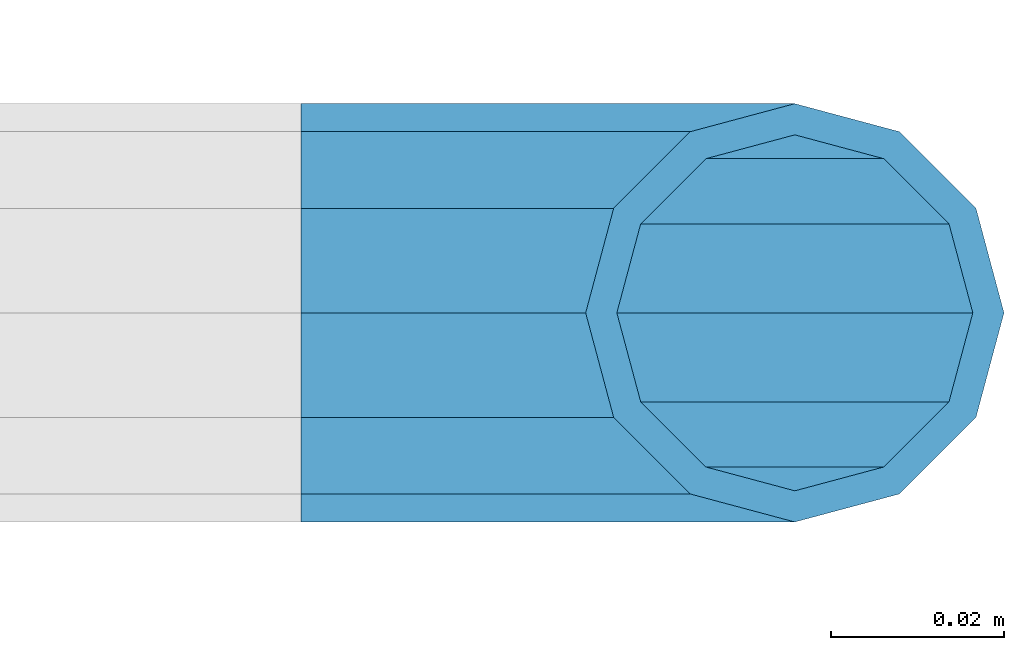
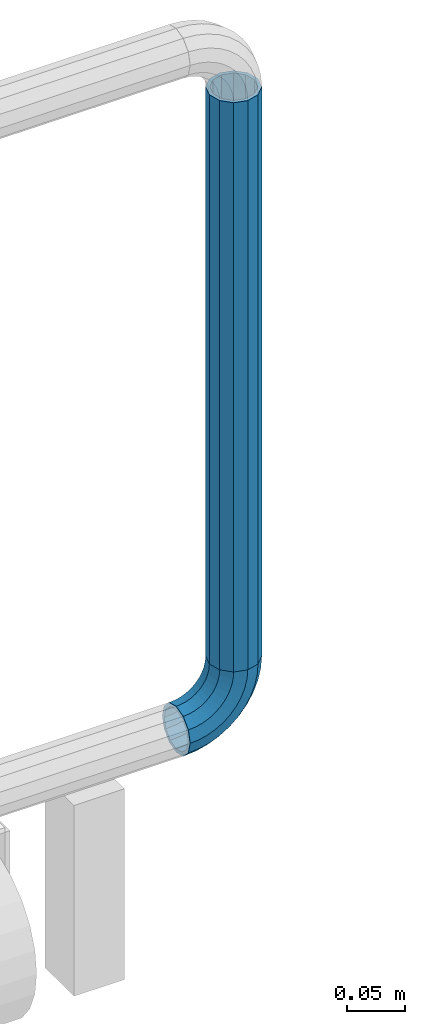
# One storey, part 179 of 247: 1 beam, 1 member.
"""IFC2X3 building model written with IfcOpenShell, lengths in millimetres."""

from ifc_helpers import new_model, si_unit, frame, origin_with_axes, place, context, subcontext, project, spatial, faceted_brep, material, type_object, element, save


model = new_model("IFC2X3")

# Units and contexts
model_context = context("Model", 3, precision=1e-05, world=origin_with_axes())
body_context = subcontext(model_context, "Body", "Model", "MODEL_VIEW")
ifc_project = project(units=[si_unit("LENGTHUNIT", "METRE", prefix="MILLI"), si_unit("AREAUNIT", "SQUARE_METRE"), si_unit("VOLUMEUNIT", "CUBIC_METRE"), si_unit("MASSUNIT", "GRAM", prefix="KILO"), si_unit("TIMEUNIT", "SECOND"), si_unit("PLANEANGLEUNIT", "RADIAN"), si_unit("SOLIDANGLEUNIT", "STERADIAN"), si_unit("THERMODYNAMICTEMPERATUREUNIT", "DEGREE_CELSIUS"), si_unit("LUMINOUSINTENSITYUNIT", "LUMEN")], contexts=[model_context])

# Site, building, storey
site_placement = place(None, origin_with_axes())
site = spatial("IfcSite", under=ifc_project, at=site_placement, CompositionType="ELEMENT")
building_placement = place(site_placement, origin_with_axes())
building = spatial("IfcBuilding", under=site, at=building_placement, Name="Standard", CompositionType="ELEMENT")
storey_placement = place(building_placement, origin_with_axes())
storey = spatial("IfcBuildingStorey", under=building, at=storey_placement, Name="Undefined", CompositionType="ELEMENT", Elevation=0.0)

# Member
ifc_material = material()
member_type = type_object("IfcMemberType", PredefinedType="NOTDEFINED")
member_placement = place(storey_placement, frame((30329.9462613762, 8941.85337247848, 281.650006544463), z_axis=(0.0, -0.999999999999548, -9.5100000000016e-07), x_axis=(-0.707106773186475, 4.52999999771556e-07, -0.707106789186475)))
element("IfcMember", 1, at=member_placement, inside=storey, type_object=member_type, material=ifc_material, context=body_context, shape_type="Brep", body=[
    faceted_brep([(17.0766287656552, -17.0766287656515, 0.0), (14.7887943220521, -14.7887943220485, -12.0749999999998), (19.0945697419556, -11.1113146999705, -12.0749999999998), (20.9963409898264, -13.7288782624128, 0.0), (8.53831438282941, -8.53831438282577, -20.9145135013941), (13.8988340683936, -3.95999805533575, -20.9145135013941), (0.0, 3.63797880709171e-12, -24.1499999999996), (6.80132714696083, 5.80888215174127, -24.1499999999996), (-8.53831438282577, 8.53831438282941, -20.9145135013941), (-0.296179774468328, 15.5777623588219, -20.9145135013941), (-14.7887943220521, 14.7887943220558, -12.0749999999998), (-5.4919154480267, 22.7290790034531, -12.0749999999998), (-17.0766287656552, 17.0766287656588, 0.0), (-7.39368669590112, 25.3466425658989, 0.0), (-14.7887943220521, 14.7887943220558, 12.0749999999998), (-5.4919154480267, 22.7290790034531, 12.0749999999998), (-8.53831438282577, 8.53831438282941, 20.9145135013941), (-0.296179774468328, 15.5777623588219, 20.9145135013941), (0.0, 3.63797880709171e-12, 24.1499999999996), (6.80132714696083, 5.80888215174127, 24.1499999999996), (8.53831438282941, -8.53831438282577, 20.9145135013941), (13.8988340683936, -3.95999805533575, 20.9145135013941), (14.7887943220521, -14.7887943220485, 12.0749999999998), (19.0945697419556, -11.1113146999705, 12.0749999999998), (14.5310443533854, -14.5310443533817, 0.0), (12.5842535535485, -12.5842535535448, 10.2749999999996), (17.2620366843148, -8.58904933077429, 10.2749999999996), (18.8803140815726, -10.8164170826603, 0.0), (7.26552217669087, -7.26552217668723, 17.7968220477705), (12.8408206142667, -2.50376746545953, 17.7968220477705), (0.0, 3.63797880709171e-12, 20.5500000000002), (6.80132714696083, 5.80888215174127, 20.5500000000002), (-7.26552217669087, 7.2655221766945, 17.7968220477705), (0.761833679654956, 14.1215317689421, 17.7968220477705), (-12.5842535535485, 12.5842535535521, 10.2749999999996), (-3.65938239038951, 20.2068136342532, 10.2749999999996), (-14.5310443533817, 14.5310443533854, 0.0), (-5.27765978764728, 22.4341813861465, 0.0), (-12.5842535535485, 12.5842535535521, -10.2749999999996), (-3.65938239038951, 20.2068136342532, -10.2749999999996), (-7.26552217669087, 7.2655221766945, -17.7968220477705), (0.761833679654956, 14.1215317689421, -17.7968220477705), (0.0, 3.63797880709171e-12, -20.5500000000002), (6.80132714696083, 5.80888215174127, -20.5500000000002), (7.26552217669087, -7.26552217668723, -17.7968220477705), (12.8408206142667, -2.50376746545953, -17.7968220477705), (12.5842535535485, -12.5842535535448, -10.2749999999996), (17.2620366843148, -8.58904933077429, -10.2749999999996), (23.922618478784, -8.15268262886457, -12.0749999999998), (25.3914986111849, -11.0355222080434, 0.0), (19.9095633268335, -0.276618428470101, -20.9145135013941), (14.4276280424783, 10.4822853511068, -24.1499999999996), (8.94569275812319, 21.2411891306838, -20.9145135013941), (4.93263760616901, 29.1172533310746, -12.0749999999998), (3.46375747376806, 32.0000929102534, 0.0), (4.93263760616901, 29.1172533310746, 12.0749999999998), (8.94569275812319, 21.2411891306838, 20.9145135013941), (14.4276280424783, 10.4822853511068, 24.1499999999996), (19.9095633268335, -0.276618428470101, 20.9145135013941), (23.922618478784, -8.15268262886457, 12.0749999999998), (22.5072161777207, -5.37479920327678, 10.2749999999996), (23.7571328121303, -7.82789872096328, 0.0), (19.0923804273007, 1.32719331506814, 17.7968220477705), (14.4276280424783, 10.4822853511068, 20.5500000000002), (9.76287565765597, 19.6373773871455, 17.7968220477705), (6.34803990723594, 26.3393699054905, 10.2749999999996), (5.09812327282998, 28.7924694231733, 0.0), (6.34803990723594, 26.3393699054905, -10.2749999999996), (9.76287565765597, 19.6373773871455, -17.7968220477705), (14.4276280424783, 10.4822853511068, -20.5500000000002), (19.0923804273007, 1.32719331506814, -17.7968220477705), (22.5072161777207, -5.37479920327678, -10.2749999999996), (29.1540579492757, -5.98574944944994, -12.0749999999998), (30.1538782624157, -9.0628799673359, 0.0), (26.4224980553372, 2.42112746692874, -20.9145135013941), (22.6911178482587, 13.9051349011934, -24.1499999999996), (18.9597376411839, 25.3891423354544, -20.9145135013941), (16.228177747249, 33.7960192518367, -12.0749999999998), (15.2283574341054, 36.873149769719, 0.0), (16.228177747249, 33.7960192518367, 12.0749999999998), (18.9597376411839, 25.3891423354544, 20.9145135013941), (22.6911178482587, 13.9051349011934, 24.1499999999996), (26.4224980553372, 2.42112746692874, 20.9145135013941), (29.1540579492757, -5.98574944944994, 12.0749999999998), (28.190638306889, -3.02064867668378, 10.2749999999996), (29.0414170826662, -5.63907650866895, 0.0), (25.8662674654624, 4.13302919626221, 17.7968220477705), (22.6911178482587, 13.9051349011934, 20.5500000000002), (19.5159682310587, 23.6772406061282, 17.7968220477705), (17.1915973896357, 30.8309184790705, 10.2749999999996), (16.3408186138549, 33.4493463110593, 0.0), (17.1915973896357, 30.8309184790705, -10.2749999999996), (19.5159682310587, 23.6772406061282, -17.7968220477705), (22.6911178482587, 13.9051349011934, -20.5500000000002), (25.8662674654624, 4.13302919626221, -17.7968220477705), (28.190638306889, -3.02064867668378, -10.2749999999996), (34.660072751507, -4.66387224825303, -12.0749999999998), (35.1662143510621, -7.85952453907885, 0.0), (33.2772681857023, 4.06681217360529, -20.9145135013941), (31.3883220203388, 15.9931488862931, -24.1499999999996), (29.499375854979, 27.9194855989772, -20.9145135013941), (28.1165712891707, 36.6501700208391, -12.0749999999998), (27.6104296896192, 39.8458223116686, 0.0), (28.1165712891707, 36.6501700208391, 12.0749999999998), (29.499375854979, 27.9194855989772, 20.9145135013941), (31.3883220203388, 15.9931488862931, 24.1499999999996), (33.2772681857023, 4.06681217360529, 20.9145135013941), (34.660072751507, -4.66387224825303, 12.0749999999998), (34.1723583567982, -1.58456474993727, 10.2749999999996), (34.6030502769172, -4.30384651293571, 0.0), (32.995686148628, 5.84465118667504, 17.7968220477705), (31.3883220203388, 15.9931488862931, 20.5500000000002), (29.7809578920533, 26.1416465859074, 17.7968220477705), (28.6042856838794, 33.5708625225234, 10.2749999999996), (28.1735937637641, 36.2901442855255, 0.0), (28.6042856838794, 33.5708625225234, -10.2749999999996), (29.7809578920533, 26.1416465859074, -17.7968220477705), (31.3883220203388, 15.9931488862931, -20.5500000000002), (32.995686148628, 5.84465118667504, -17.7968220477705), (34.1723583567982, -1.58456474993727, -10.2749999999996), (40.3050865276309, -4.21960002902415, -12.0749999999998), (40.3050865276346, -7.45508652763237, 0.0), (40.3050865276309, 4.61991347236835, -20.9145135013941), (40.3050865276346, 16.6949134723691, -24.1499999999996), (40.3050865276309, 28.7699134723698, -20.9145135013941), (40.3050865276309, 37.6094269737623, -12.0749999999998), (40.3050865276346, 40.8449134723705, 0.0), (40.3050865276309, 37.6094269737623, 12.0749999999998), (40.3050865276309, 28.7699134723698, 20.9145135013941), (40.3050865276346, 16.6949134723691, 24.1499999999996), (40.3050865276309, 4.61991347236835, 20.9145135013941), (40.3050865276309, -4.21960002902415, 12.0749999999998), (40.3050865276346, -1.10190857540147, 10.2749999999996), (40.3050865276309, -3.85508652763019, 0.0), (40.3050865276346, 6.41991347236763, 17.7968220477705), (40.3050865276346, 16.6949134723691, 20.5500000000002), (40.3050865276346, 26.9699134723705, 17.7968220477705), (40.3050865276346, 34.4917355201396, 10.2749999999996), (40.3050865276309, 37.2449134723684, 0.0), (40.3050865276346, 34.4917355201396, -10.2749999999996), (40.3050865276346, 26.9699134723705, -17.7968220477705), (40.3050865276346, 16.6949134723691, -20.5500000000002), (40.3050865276346, 6.41991347236763, -17.7968220477705), (40.3050865276346, -1.10190857540147, -10.2749999999996), (45.9501003037585, -4.66387224825667, -12.0749999999998), (45.443958704207, -7.85952453907885, 0.0), (47.3329048695668, 4.06681217360529, -20.9145135013941), (49.2218510349267, 15.9931488862894, -24.1499999999996), (51.1107972002865, 27.9194855989808, -20.9145135013941), (52.4936017660912, 36.6501700208391, -12.0749999999998), (52.9997433656463, 39.845822311665, 0.0), (52.4936017660912, 36.6501700208391, 12.0749999999998), (51.1107972002865, 27.9194855989808, 20.9145135013941), (49.2218510349267, 15.9931488862894, 24.1499999999996), (47.3329048695668, 4.06681217360529, 20.9145135013941), (45.9501003037585, -4.66387224825667, 12.0749999999998), (46.4378146984673, -1.58456474993363, 10.2749999999996), (46.0071227783483, -4.30384651293934, 0.0), (47.6144869066338, 5.84465118667504, 17.7968220477705), (49.2218510349267, 15.9931488862894, 20.5500000000002), (50.8292151632122, 26.1416465859038, 17.7968220477705), (52.0058873713861, 33.5708625225197, 10.2749999999996), (52.4365792915014, 36.2901442855218, 0.0), (52.0058873713861, 33.5708625225197, -10.2749999999996), (50.8292151632122, 26.1416465859038, -17.7968220477705), (49.2218510349267, 15.9931488862894, -20.5500000000002), (47.6144869066338, 5.84465118667504, -17.7968220477705), (46.4378146984673, -1.58456474993363, -10.2749999999996), (51.4561151059934, -5.98574944944994, -12.0749999999998), (50.4562947928498, -9.06287996733226, 0.0), (54.1876749999246, 2.42112746692874, -20.9145135013941), (57.9190552070031, 13.9051349011934, -24.1499999999996), (61.6504354140816, 25.389142335458, -20.9145135013941), (64.3819953080201, 33.7960192518367, -12.0749999999998), (65.3818156211564, 36.873149769719, 0.0), (64.3819953080201, 33.7960192518367, 12.0749999999998), (61.6504354140816, 25.389142335458, 20.9145135013941), (57.9190552070031, 13.9051349011934, 24.1499999999996), (54.1876749999246, 2.42112746692874, 20.9145135013941), (51.4561151059934, -5.98574944944994, 12.0749999999998), (52.4195347483801, -3.02064867668378, 10.2749999999996), (51.5687559725993, -5.63907650867259, 0.0), (54.743905589803, 4.13302919625858, 17.7968220477705), (57.9190552070031, 13.9051349011934, 20.5500000000002), (61.0942048242068, 23.6772406061245, 17.7968220477705), (63.4185756656334, 30.8309184790705, 10.2749999999996), (64.2693544414105, 33.4493463110557, 0.0), (63.4185756656334, 30.8309184790705, -10.2749999999996), (61.0942048242068, 23.6772406061245, -17.7968220477705), (57.9190552070031, 13.9051349011934, -20.5500000000002), (54.743905589803, 4.13302919625858, -17.7968220477705), (52.4195347483801, -3.02064867668378, -10.2749999999996), (56.6875545764815, -8.15268262886093, -12.0749999999998), (55.2186744440769, -11.0355222080434, 0.0), (60.700609728432, -0.276618428466463, -20.9145135013941), (66.1825450127908, 10.4822853511068, -24.1499999999996), (71.6644802971423, 21.2411891306801, -20.9145135013941), (75.6775354490928, 29.1172533310746, -12.0749999999998), (77.1464155814938, 32.0000929102534, 0.0), (75.6775354490928, 29.1172533310746, 12.0749999999998), (71.6644802971423, 21.2411891306801, 20.9145135013941), (66.1825450127908, 10.4822853511068, 24.1499999999996), (60.700609728432, -0.276618428466463, 20.9145135013941), (56.6875545764815, -8.15268262886093, 12.0749999999998), (58.1029568775448, -5.37479920327314, 10.2749999999996), (56.8530402431388, -7.82789872096328, 0.0), (61.5177926279612, 1.32719331506814, 17.7968220477705), (66.1825450127908, 10.4822853511068, 20.5500000000002), (70.8472973976095, 19.6373773871419, 17.7968220477705), (74.2621331480295, 26.3393699054868, 10.2749999999996), (75.5120497824355, 28.792469423177, 0.0), (74.2621331480295, 26.3393699054868, -10.2749999999996), (70.8472973976095, 19.6373773871419, -17.7968220477705), (66.1825450127908, 10.4822853511068, -20.5500000000002), (61.5177926279612, 1.32719331506814, -17.7968220477705), (58.1029568775448, -5.37479920327314, -10.2749999999996), (61.5156033133135, -11.1113146999705, -12.0749999999998), (59.6138320654427, -13.7288782624128, 0.0), (66.7113389868719, -3.95999805533938, -20.9145135013941), (73.8088459083046, 5.80888215174491, -24.1499999999996), (80.9063528297338, 15.5777623588183, -20.9145135013941), (86.1020885032958, 22.7290790034531, -12.0749999999998), (88.0038597511666, 25.3466425658953, 0.0), (86.1020885032958, 22.7290790034531, 12.0749999999998), (80.9063528297338, 15.5777623588183, 20.9145135013941), (73.8088459083046, 5.80888215174491, 24.1499999999996), (66.7113389868719, -3.95999805533938, 20.9145135013941), (61.5156033133135, -11.1113146999705, 12.0749999999998), (63.3481363709507, -8.58904933077065, 10.2749999999996), (61.7298589736929, -10.816417082664, 0.0), (67.7693524410024, -2.50376746545953, 17.7968220477705), (73.8088459083046, 5.80888215174491, 20.5500000000002), (79.8483393756105, 14.1215317689457, 17.7968220477705), (84.2695554456586, 20.2068136342532, 10.2749999999996), (85.8878328429164, 22.4341813861465, 0.0), (84.2695554456586, 20.2068136342532, -10.2749999999996), (79.8483393756105, 14.1215317689457, -17.7968220477705), (73.8088459083046, 5.80888215174491, -20.5500000000002), (67.7693524410024, -2.50376746545953, -17.7968220477705), (63.3481363709507, -8.58904933077065, -10.2749999999996), (65.8213787332134, -14.7887943220521, -12.0749999999998), (63.5335442896103, -17.0766287656552, 0.0), (72.0718586724397, -8.53831438282577, -20.9145135013941), (80.6101730552655, 0.0, -24.1499999999996), (89.1484874380949, 8.53831438282941, -20.9145135013941), (95.3989673773212, 14.7887943220558, -12.0749999999998), (97.6868018209243, 17.0766287656588, 0.0), (95.3989673773212, 14.7887943220558, 12.0749999999998), (89.1484874380949, 8.53831438282941, 20.9145135013941), (80.6101730552655, 0.0, 24.1499999999996), (72.0718586724397, -8.53831438282577, 20.9145135013941), (65.8213787332134, -14.7887943220521, 12.0749999999998), (68.025919501717, -12.5842535535485, 10.2749999999996), (66.0791287018837, -14.5310443533817, 0.0), (73.3446508785746, -7.26552217669087, 17.7968220477705), (80.6101730552655, 0.0, 20.5500000000002), (87.87569523196, 7.2655221766945, 17.7968220477705), (93.1944266088176, 12.5842535535521, 10.2749999999996), (95.1412174086508, 14.5310443533854, 0.0), (93.1944266088176, 12.5842535535521, -10.2749999999996), (87.87569523196, 7.2655221766945, -17.7968220477705), (80.6101730552655, 0.0, -20.5500000000002), (73.3446508785746, -7.26552217669087, -17.7968220477705), (68.025919501717, -12.5842535535485, -10.2749999999996)], [[[0, 1, 2, 3]], [[1, 4, 5, 2]], [[4, 6, 7, 5]], [[6, 8, 9, 7]], [[8, 10, 11, 9]], [[10, 12, 13, 11]], [[12, 14, 15, 13]], [[14, 16, 17, 15]], [[16, 18, 19, 17]], [[18, 20, 21, 19]], [[20, 22, 23, 21]], [[22, 0, 3, 23]], [[24, 25, 26, 27]], [[25, 28, 29, 26]], [[28, 30, 31, 29]], [[30, 32, 33, 31]], [[32, 34, 35, 33]], [[34, 36, 37, 35]], [[36, 38, 39, 37]], [[38, 40, 41, 39]], [[40, 42, 43, 41]], [[42, 44, 45, 43]], [[44, 46, 47, 45]], [[46, 24, 27, 47]], [[22, 20, 18, 16, 14, 12, 10, 8, 6, 4, 1, 0], [46, 44, 42, 40, 38, 36, 34, 32, 30, 28, 25, 24]], [[3, 2, 48, 49]], [[2, 5, 50, 48]], [[5, 7, 51, 50]], [[7, 9, 52, 51]], [[9, 11, 53, 52]], [[11, 13, 54, 53]], [[13, 15, 55, 54]], [[15, 17, 56, 55]], [[17, 19, 57, 56]], [[19, 21, 58, 57]], [[21, 23, 59, 58]], [[23, 3, 49, 59]], [[27, 26, 60, 61]], [[26, 29, 62, 60]], [[29, 31, 63, 62]], [[31, 33, 64, 63]], [[33, 35, 65, 64]], [[35, 37, 66, 65]], [[37, 39, 67, 66]], [[39, 41, 68, 67]], [[41, 43, 69, 68]], [[43, 45, 70, 69]], [[45, 47, 71, 70]], [[47, 27, 61, 71]], [[49, 48, 72, 73]], [[48, 50, 74, 72]], [[50, 51, 75, 74]], [[51, 52, 76, 75]], [[52, 53, 77, 76]], [[53, 54, 78, 77]], [[54, 55, 79, 78]], [[55, 56, 80, 79]], [[56, 57, 81, 80]], [[57, 58, 82, 81]], [[58, 59, 83, 82]], [[59, 49, 73, 83]], [[61, 60, 84, 85]], [[60, 62, 86, 84]], [[62, 63, 87, 86]], [[63, 64, 88, 87]], [[64, 65, 89, 88]], [[65, 66, 90, 89]], [[66, 67, 91, 90]], [[67, 68, 92, 91]], [[68, 69, 93, 92]], [[69, 70, 94, 93]], [[70, 71, 95, 94]], [[71, 61, 85, 95]], [[73, 72, 96, 97]], [[72, 74, 98, 96]], [[74, 75, 99, 98]], [[75, 76, 100, 99]], [[76, 77, 101, 100]], [[77, 78, 102, 101]], [[78, 79, 103, 102]], [[79, 80, 104, 103]], [[80, 81, 105, 104]], [[81, 82, 106, 105]], [[82, 83, 107, 106]], [[83, 73, 97, 107]], [[85, 84, 108, 109]], [[84, 86, 110, 108]], [[86, 87, 111, 110]], [[87, 88, 112, 111]], [[88, 89, 113, 112]], [[89, 90, 114, 113]], [[90, 91, 115, 114]], [[91, 92, 116, 115]], [[92, 93, 117, 116]], [[93, 94, 118, 117]], [[94, 95, 119, 118]], [[95, 85, 109, 119]], [[97, 96, 120, 121]], [[96, 98, 122, 120]], [[98, 99, 123, 122]], [[99, 100, 124, 123]], [[100, 101, 125, 124]], [[101, 102, 126, 125]], [[102, 103, 127, 126]], [[103, 104, 128, 127]], [[104, 105, 129, 128]], [[105, 106, 130, 129]], [[106, 107, 131, 130]], [[107, 97, 121, 131]], [[109, 108, 132, 133]], [[108, 110, 134, 132]], [[110, 111, 135, 134]], [[111, 112, 136, 135]], [[112, 113, 137, 136]], [[113, 114, 138, 137]], [[114, 115, 139, 138]], [[115, 116, 140, 139]], [[116, 117, 141, 140]], [[117, 118, 142, 141]], [[118, 119, 143, 142]], [[119, 109, 133, 143]], [[121, 120, 144, 145]], [[120, 122, 146, 144]], [[122, 123, 147, 146]], [[123, 124, 148, 147]], [[124, 125, 149, 148]], [[125, 126, 150, 149]], [[126, 127, 151, 150]], [[127, 128, 152, 151]], [[128, 129, 153, 152]], [[129, 130, 154, 153]], [[130, 131, 155, 154]], [[131, 121, 145, 155]], [[133, 132, 156, 157]], [[132, 134, 158, 156]], [[134, 135, 159, 158]], [[135, 136, 160, 159]], [[136, 137, 161, 160]], [[137, 138, 162, 161]], [[138, 139, 163, 162]], [[139, 140, 164, 163]], [[140, 141, 165, 164]], [[141, 142, 166, 165]], [[142, 143, 167, 166]], [[143, 133, 157, 167]], [[145, 144, 168, 169]], [[144, 146, 170, 168]], [[146, 147, 171, 170]], [[147, 148, 172, 171]], [[148, 149, 173, 172]], [[149, 150, 174, 173]], [[150, 151, 175, 174]], [[151, 152, 176, 175]], [[152, 153, 177, 176]], [[153, 154, 178, 177]], [[154, 155, 179, 178]], [[155, 145, 169, 179]], [[157, 156, 180, 181]], [[156, 158, 182, 180]], [[158, 159, 183, 182]], [[159, 160, 184, 183]], [[160, 161, 185, 184]], [[161, 162, 186, 185]], [[162, 163, 187, 186]], [[163, 164, 188, 187]], [[164, 165, 189, 188]], [[165, 166, 190, 189]], [[166, 167, 191, 190]], [[167, 157, 181, 191]], [[169, 168, 192, 193]], [[168, 170, 194, 192]], [[170, 171, 195, 194]], [[171, 172, 196, 195]], [[172, 173, 197, 196]], [[173, 174, 198, 197]], [[174, 175, 199, 198]], [[175, 176, 200, 199]], [[176, 177, 201, 200]], [[177, 178, 202, 201]], [[178, 179, 203, 202]], [[179, 169, 193, 203]], [[181, 180, 204, 205]], [[180, 182, 206, 204]], [[182, 183, 207, 206]], [[183, 184, 208, 207]], [[184, 185, 209, 208]], [[185, 186, 210, 209]], [[186, 187, 211, 210]], [[187, 188, 212, 211]], [[188, 189, 213, 212]], [[189, 190, 214, 213]], [[190, 191, 215, 214]], [[191, 181, 205, 215]], [[193, 192, 216, 217]], [[192, 194, 218, 216]], [[194, 195, 219, 218]], [[195, 196, 220, 219]], [[196, 197, 221, 220]], [[197, 198, 222, 221]], [[198, 199, 223, 222]], [[199, 200, 224, 223]], [[200, 201, 225, 224]], [[201, 202, 226, 225]], [[202, 203, 227, 226]], [[203, 193, 217, 227]], [[205, 204, 228, 229]], [[204, 206, 230, 228]], [[206, 207, 231, 230]], [[207, 208, 232, 231]], [[208, 209, 233, 232]], [[209, 210, 234, 233]], [[210, 211, 235, 234]], [[211, 212, 236, 235]], [[212, 213, 237, 236]], [[213, 214, 238, 237]], [[214, 215, 239, 238]], [[215, 205, 229, 239]], [[217, 216, 240, 241]], [[216, 218, 242, 240]], [[218, 219, 243, 242]], [[219, 220, 244, 243]], [[220, 221, 245, 244]], [[221, 222, 246, 245]], [[222, 223, 247, 246]], [[223, 224, 248, 247]], [[224, 225, 249, 248]], [[225, 226, 250, 249]], [[226, 227, 251, 250]], [[227, 217, 241, 251]], [[229, 228, 252, 253]], [[228, 230, 254, 252]], [[230, 231, 255, 254]], [[231, 232, 256, 255]], [[232, 233, 257, 256]], [[233, 234, 258, 257]], [[234, 235, 259, 258]], [[235, 236, 260, 259]], [[236, 237, 261, 260]], [[237, 238, 262, 261]], [[238, 239, 263, 262]], [[239, 229, 253, 263]], [[242, 243, 244, 245, 246, 247, 248, 249, 250, 251, 241, 240], [254, 255, 256, 257, 258, 259, 260, 261, 262, 263, 253, 252]]]),
])

# Beam
beam_type = type_object("IfcBeamType", PredefinedType="NOTDEFINED")
beam_placement = place(storey_placement, frame((30329.9462613762, 8941.85337247848, 878.350006544462), z_axis=(1.0, 0.0, 0.0), x_axis=(0.0, 0.0, -1.0)))
element("IfcBeam", 2, at=beam_placement, inside=storey, type_object=beam_type, material=ifc_material, context=body_context, shape_type="Brep", body=[
    faceted_brep([(0.0, -20.5500000000002, 0.0), (0.0, -17.7968220477705, 10.2750000000015), (596.700000000001, -17.7968220477705, 10.2750000000015), (596.700000000001, -20.5500000000002, 0.0), (0.0, -10.2749999999996, 17.7968220477705), (596.700000000001, -10.2749999999996, 17.7968220477705), (0.0, 3.63797880709171e-12, 20.5500000000002), (596.700000000001, 0.0, 20.5499999999993), (0.0, 10.2749999999996, 17.7968220477705), (596.700000000001, 10.2749999999996, 17.7968220477705), (0.0, 17.7968220477705, 10.2750000000015), (596.700000000001, 17.7968220477705, 10.2750000000015), (0.0, 20.5500000000002, 0.0), (596.700000000001, 20.5500000000002, 0.0), (0.0, 17.7968220477705, -10.2750000000015), (596.700000000001, 17.7968220477705, -10.2750000000015), (0.0, 10.2749999999996, -17.7968220477705), (596.700000000001, 10.2749999999996, -17.7968220477705), (0.0, 3.63797880709171e-12, -20.5500000000002), (596.700000000001, 0.0, -20.5499999999993), (0.0, -10.2749999999996, -17.7968220477705), (596.700000000001, -10.2749999999996, -17.7968220477705), (0.0, -17.7968220477705, -10.2750000000015), (596.700000000001, -17.7968220477705, -10.2750000000015), (0.0, -24.1499999999996, 0.0), (0.0, -20.9145135013941, -12.0750000000007), (596.700000000001, -20.9145135013941, -12.0750000000007), (596.700000000001, -24.1499999999996, 0.0), (0.0, -12.0749999999998, -20.9145135013932), (596.700000000001, -12.0749999999998, -20.9145135013932), (0.0, 3.63797880709171e-12, -24.1499999999996), (596.700000000001, 0.0, -24.1500000000015), (0.0, 12.0749999999998, -20.9145135013932), (596.700000000001, 12.0749999999998, -20.9145135013932), (0.0, 20.9145135013941, -12.0750000000007), (596.700000000001, 20.9145135013941, -12.0750000000007), (0.0, 24.1499999999996, 0.0), (596.700000000001, 24.1499999999996, 0.0), (0.0, 20.9145135013941, 12.0750000000007), (596.700000000001, 20.9145135013941, 12.0750000000007), (0.0, 12.0749999999998, 20.9145135013932), (596.700000000001, 12.0749999999998, 20.9145135013932), (0.0, 3.63797880709171e-12, 24.1499999999996), (596.700000000001, 0.0, 24.1500000000015), (0.0, -12.0749999999998, 20.9145135013932), (596.700000000001, -12.0749999999998, 20.9145135013932), (0.0, -20.9145135013941, 12.0750000000007), (596.700000000001, -20.9145135013941, 12.0750000000007)], [[[0, 1, 2, 3]], [[1, 4, 5, 2]], [[4, 6, 7, 5]], [[6, 8, 9, 7]], [[8, 10, 11, 9]], [[10, 12, 13, 11]], [[12, 14, 15, 13]], [[14, 16, 17, 15]], [[16, 18, 19, 17]], [[18, 20, 21, 19]], [[20, 22, 23, 21]], [[22, 0, 3, 23]], [[24, 25, 26, 27]], [[25, 28, 29, 26]], [[28, 30, 31, 29]], [[30, 32, 33, 31]], [[32, 34, 35, 33]], [[34, 36, 37, 35]], [[36, 38, 39, 37]], [[38, 40, 41, 39]], [[40, 42, 43, 41]], [[42, 44, 45, 43]], [[44, 46, 47, 45]], [[46, 24, 27, 47]], [[29, 31, 33, 35, 37, 39, 41, 43, 45, 47, 27, 26], [5, 7, 9, 11, 13, 15, 17, 19, 21, 23, 3, 2]], [[46, 44, 42, 40, 38, 36, 34, 32, 30, 28, 25, 24], [22, 20, 18, 16, 14, 12, 10, 8, 6, 4, 1, 0]]]),
])

save(model, "model.ifc")
